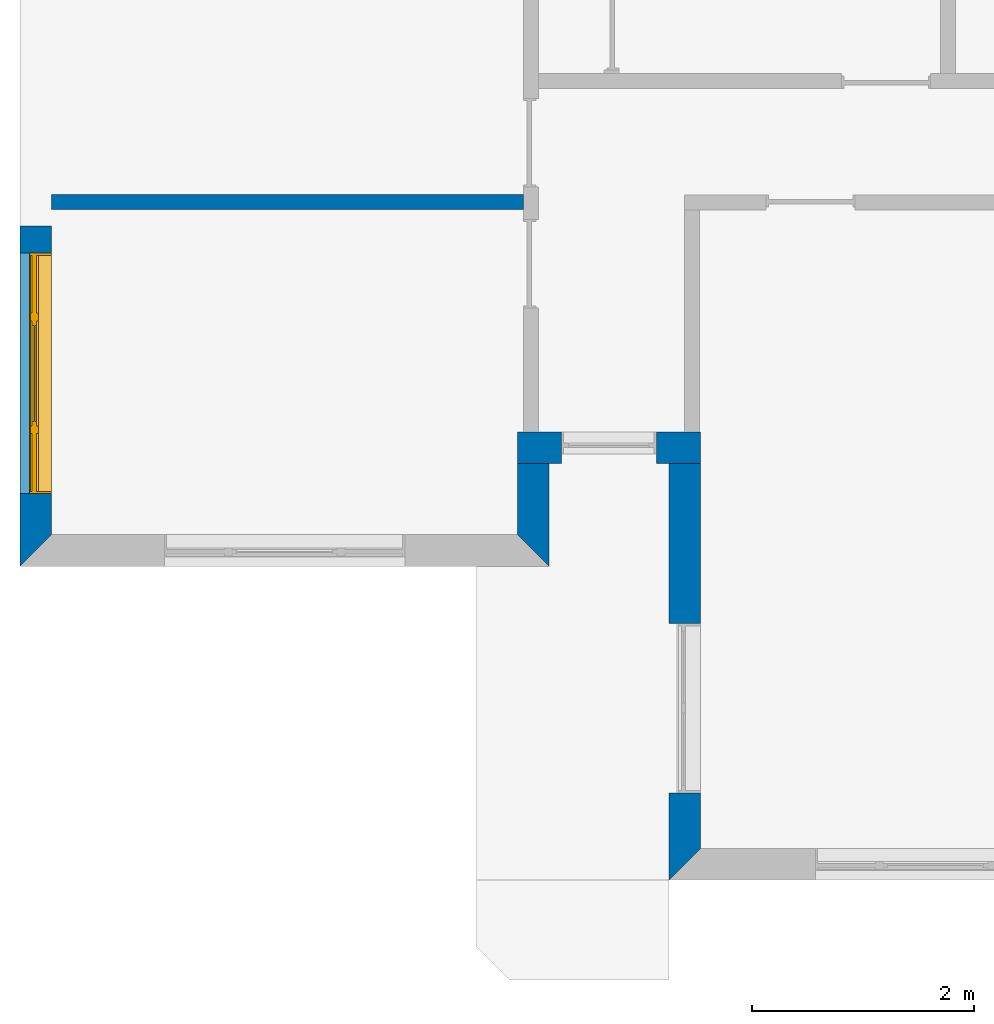
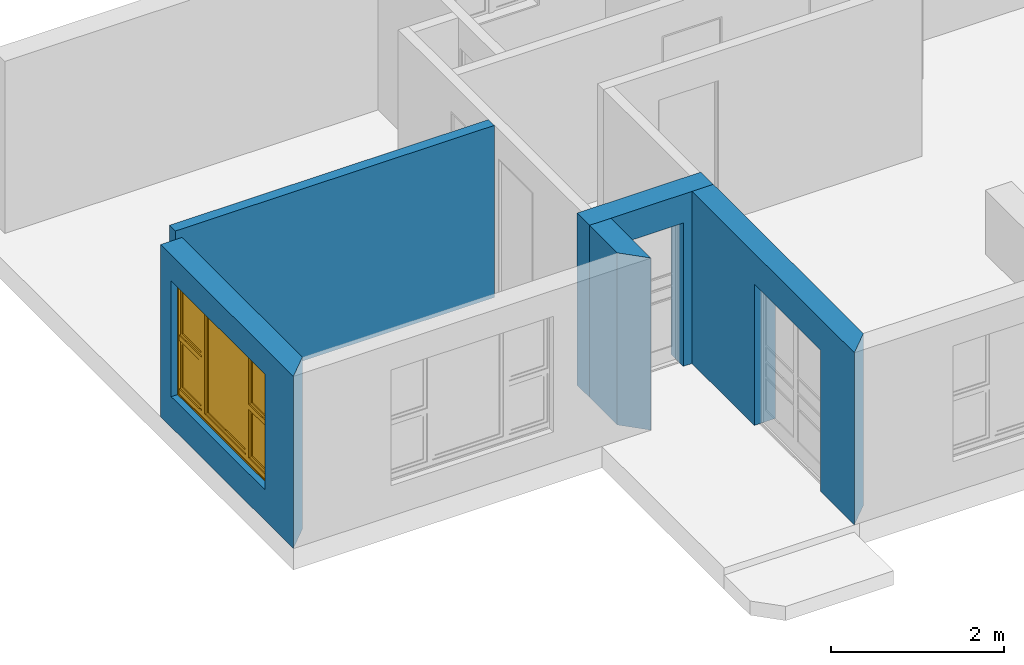
# One storey, part 2 of 15: 5 walls, 1 window, 3 openings.
"""IFC4 building model written with IfcOpenShell, lengths in millimetres."""

from ifc_helpers import new_model, entity, si_unit, converted_unit, frame, origin_with_axes, origin_2d_with_axis, place, context, subcontext, project, spatial, line, indexed_curve, outline, extrude, clip, halfspace, polygons, source, transform, mapped, material, layer, layer_set, layer_usage, type_object, type_shapes, element, fill, save


model = new_model("IFC4")

# Units and contexts
model_context = context("Model", 3, precision=1e-05, world=origin_with_axes())
plan_context = context("Plan", 2, precision=1e-05, world=origin_2d_with_axis())
body_context = subcontext(model_context, "Body", "Model", "MODEL_VIEW")
ifc_project = project(units=[si_unit("VOLUMEUNIT", "CUBIC_METRE"), si_unit("LENGTHUNIT", "METRE", prefix="MILLI"), converted_unit("PLANEANGLEUNIT", "degree", entity("IfcReal", 0.0174532925199433), si_unit("PLANEANGLEUNIT", "RADIAN"), dimensions=[0, 0, 0, 0, 0, 0, 0]), si_unit("AREAUNIT", "SQUARE_METRE")], contexts=[model_context, plan_context])

# Site, building, storey
site_placement = place(None, origin_with_axes())
site = spatial("IfcSite", under=ifc_project, at=site_placement)
building_placement = place(site_placement, origin_with_axes())
building = spatial("IfcBuilding", under=site, at=building_placement, Name="Building")
storey_placement = place(building_placement, origin_with_axes())
storey = spatial("IfcBuildingStorey", under=building, at=storey_placement, Name="EXISTING")

# Wall
ifc_material = material()
ifc_layer_1 = layer(ifc_material, 135.0)
ifc_layer_set_1 = layer_set([ifc_layer_1])
ifc_layer_usage_1 = layer_usage(ifc_layer_set_1, "AXIS2", "POSITIVE", 0.0)
wall_type_1 = type_object("IfcWallType", Name="WAL135", PredefinedType="NOTDEFINED", material=ifc_layer_set_1)
wall_1_placement = place(storey_placement, frame((34.11865234375, 1521.66748046875, 0.0), z_axis=(0.0, 0.0, 1.0), x_axis=(0.999999999999993, 1.19209282445353e-07, 0.0)))
element("IfcWall", 1, at=wall_1_placement, inside=storey, type_object=wall_type_1, material=ifc_layer_usage_1, Name="Wall", context=body_context, shape_type="SweptSolid", body=[
    extrude(outline(indexed_curve([(0.0, 0.0), (0.0, 135.0), (4250.0, 135.0), (4250.0, 0.0), (0.0, 0.0)], self_intersect=False)), origin_with_axes(), (0.0, 0.0, 1.0), 2425.00019073486),
])

# Wall, opening, window
ifc_layer_2 = layer(ifc_material, 285.0, Name="brick")
ifc_layer_set_2 = layer_set([ifc_layer_2])
ifc_layer_usage_2 = layer_usage(ifc_layer_set_2, "AXIS2", "POSITIVE", 0.0)
wall_type_2 = type_object("IfcWallType", Name="285mm Wall", PredefinedType="STANDARD", material=ifc_layer_set_2)
wall_2_placement = place(storey_placement, frame((34.11865234375, -1693.33076477051, 0.0), z_axis=(0.0, 0.0, 1.0), x_axis=(3.13916473260163e-07, 0.999999999999951, 0.0)))
wall_2 = element("IfcWall", 2, at=wall_2_placement, inside=storey, type_object=wall_type_2, material=ifc_layer_usage_2, Name="Wall", context=body_context, shape_type="Clipping", body=[
    clip(extrude(outline(indexed_curve([(0.0, 0.0), (0.0, 285.0), (3064.99893064013, 285.0), (3064.99893064013, 0.0), (0.0, 0.0)], self_intersect=False)), origin_with_axes(), (0.0, 0.0, 1.0), 2425.00019073486), halfspace(frame((284.999966621399, 4.93625407216314e-06, 0.0), z_axis=(-0.70710676908493, -0.707106709480286, 0.0), x_axis=(-0.707106751384223, 0.707106810988871, 0.0)), False)),
])
shared_shape_1 = source(origin_with_axes(), body_context, "Body", "SweptSolid", [
    extrude(outline(indexed_curve([(0.0, 0.0), (2165.00024414062, 0.0), (2165.00024414062, 1629.99987792969), (0.0, 1629.99987792969)], segments=[line(1, 2, 3, 4, 1)])), frame((-1.04308121251506e-07, -600.0, 0.0), z_axis=(0.0, -1.0, 0.0), x_axis=(1.0, 0.0, 0.0)), (0.0, 0.0, -1.0), 1200.0),
])
opening_1_placement = place(wall_2_placement, frame((655.528260222358, 148.88907685485, 430.000007152557), z_axis=(0.0, 0.0, 1.0), x_axis=(1.0, -5.29395592033938e-23, 0.0)))
opening_1 = element("IfcOpeningElement", 3, at=opening_1_placement, cuts=wall_2, Name="Opening", PredefinedType="OPENING", context=body_context, shape_type="MappedRepresentation", body=[
    mapped(shared_shape_1, transform((0.0, 0.0, 0.0), x_axis=(1.0, 0.0, 0.0), y_axis=(0.0, 1.0, 0.0), z_axis=(0.0, 0.0, 1.0), scale=1.0)),
])
window_type = type_object("IfcWindowType", Name="Ex.2165x1630", PartitioningType="NOTDEFINED", PredefinedType="WINDOW")
shared_shape_2 = source(origin_with_axes(), body_context, "Body", "Tessellation", [
    polygons([(2165.00048828125, -148.88883972168, 0.0), (2165.00048828125, -148.88883972168, 19.9999198913574), (0.000134110436192714, -148.888961791992, 0.0), (0.000134110436192714, -148.888961791992, 19.9999198913574), (2165.00048828125, 51.1111831665039, 0.0), (2165.00048828125, 51.1111831665039, 19.9999198913574), (0.000134110436192714, 51.1110649108887, 0.0), (0.000134110436192714, 51.1110649108887, 19.9999198913574), (2165.00048828125, -148.88883972168, 1609.99975585938), (2165.00048828125, -148.88883972168, 1630.0), (0.000134110436192714, -148.888961791992, 1609.99975585938), (0.000134110436192714, -148.888961791992, 1630.0), (2165.00048828125, 51.1111831665039, 1609.99975585938), (2165.00048828125, 51.1111831665039, 1630.0), (0.000134110436192714, 51.1110649108887, 1609.99975585938), (0.000134110436192714, 51.1110649108887, 1630.0), (0.000134110436192714, -148.88883972168, 19.9999198913574), (20.0003528594971, -148.88883972168, 19.9999198913574), (0.000134110436192714, -148.888961791992, 1609.99975585938), (20.000114440918, -148.888961791992, 1609.99975585938), (0.000134110436192714, 51.1111831665039, 19.9999198913574), (20.000114440918, 51.1111831665039, 19.9999198913574), (-0.000104308121080976, 51.1110649108887, 1609.99975585938), (20.000114440918, 51.1110649108887, 1609.99975585938), (2145.00048828125, -148.88883972168, 19.9999198913574), (2165.00048828125, -148.88883972168, 19.9999198913574), (2145.0, -148.888961791992, 1609.99975585938), (2165.0, -148.888961791992, 1609.99975585938), (2145.00048828125, 51.1111831665039, 19.9999198913574), (2165.00048828125, 51.1111831665039, 19.9999198913574), (2145.0, 51.1110649108887, 1609.99975585938), (2165.0, 51.1110649108887, 1609.99975585938), (1554.99987792969, -28.8888530731201, 19.9999198913574), (1625.0, -28.8888530731201, 19.9999198913574), (1554.99938964844, -28.8888530731201, 1609.99975585938), (1624.99951171875, -28.8888530731201, 1609.99975585938), (1554.99987792969, 41.1110763549805, 19.9999198913574), (1625.0, 41.1110763549805, 19.9999198913574), (1554.99938964844, 41.1110763549805, 1609.99975585938), (1624.99951171875, 41.1110763549805, 1609.99975585938), (540.000061035156, -28.8888530731201, 19.9999198913574), (610.000244140625, -28.8888530731201, 19.9999198913574), (539.999816894531, -28.8888530731201, 1609.99975585938), (610.0, -28.8888530731201, 1609.99975585938), (540.000061035156, 41.1110763549805, 19.9999198913574), (610.000244140625, 41.1110763549805, 19.9999198913574), (539.999816894531, 41.1110763549805, 1609.99975585938), (610.0, 41.1110763549805, 1609.99975585938), (20.000114440918, -28.888973236084, 844.999328613281), (20.000114440918, -28.888973236084, 775.000122070312), (540.000061035156, -28.8888530731201, 845.000061035156), (540.000061035156, -28.8888530731201, 775.000793457031), (20.000114440918, 41.1110763549805, 844.999328613281), (20.000114440918, 41.1110763549805, 775.000122070312), (540.000061035156, 41.1110763549805, 845.000061035156), (540.000061035156, 41.1111946105957, 775.000793457031), (1625.0, -28.888973236084, 844.999328613281), (1625.0, -28.888973236084, 775.000122070312), (2145.0, -28.8888530731201, 845.000061035156), (2145.0, -28.8888530731201, 775.000793457031), (1625.0, 41.1110763549805, 844.999328613281), (1625.0, 41.1110763549805, 775.000122070312), (2145.0, 41.1110763549805, 845.000061035156), (2145.0, 41.1111946105957, 775.000793457031), (1625.0, -13.8889875411987, 1609.99951171875), (1625.0, -13.8889875411987, 1569.99987792969), (2145.0, -13.8888683319092, 1609.99975585938), (2145.0, -13.8888683319092, 1570.00061035156), (1625.0, 26.1110916137695, 1609.99951171875), (1625.0, 26.1110916137695, 1569.99987792969), (2145.0, 26.1110916137695, 1610.00024414062), (2145.0, 26.1110916137695, 1570.00061035156), (1625.0, -13.8889875411987, 884.9990234375), (1625.0, -13.8889875411987, 844.999328613281), (2145.0, -13.8888683319092, 884.99951171875), (2145.0, -13.8888683319092, 844.999938964844), (1625.0, 26.1110916137695, 884.9990234375), (1625.0, 26.1110916137695, 844.999328613281), (2145.0, 26.1110916137695, 884.99951171875), (2145.0, 26.1110916137695, 844.999938964844), (1665.0, -13.8888683319092, 1570.00012207031), (1625.0, -13.8888683319092, 1570.00012207031), (1664.99975585938, -13.8888683319092, 884.9990234375), (1625.0, -13.8888683319092, 884.9990234375), (1665.0, 26.1110916137695, 1570.00012207031), (1625.0, 26.1110916137695, 1570.00012207031), (1664.99975585938, 26.1110916137695, 884.9990234375), (1625.0, 26.1110916137695, 884.9990234375), (2144.99951171875, -13.8888683319092, 1570.00012207031), (2105.00024414062, -13.8888683319092, 1570.00012207031), (2144.99951171875, -13.8888683319092, 884.9990234375), (2104.99975585938, -13.8888683319092, 884.9990234375), (2144.99951171875, 26.1110916137695, 1570.00012207031), (2105.00024414062, 26.1110916137695, 1570.00012207031), (2144.99951171875, 26.1110916137695, 884.9990234375), (2104.99975585938, 26.1110916137695, 884.9990234375), (20.0003528594971, -13.8889875411987, 1609.99951171875), (20.0003528594971, -13.8889875411987, 1569.99987792969), (540.000305175781, -13.8888683319092, 1609.99975585938), (540.000305175781, -13.8888683319092, 1570.00061035156), (20.0003528594971, 26.1110916137695, 1609.99951171875), (20.0003528594971, 26.1110916137695, 1569.99987792969), (540.000305175781, 26.1110916137695, 1610.00024414062), (540.000305175781, 26.1110916137695, 1570.00061035156), (20.0003528594971, -13.8889875411987, 884.9990234375), (20.0003528594971, -13.8889875411987, 844.999328613281), (540.000305175781, -13.8888683319092, 884.99951171875), (540.000305175781, -13.8888683319092, 844.999938964844), (20.0003528594971, 26.1110916137695, 884.9990234375), (20.0003528594971, 26.1110916137695, 844.999328613281), (540.000305175781, 26.1110916137695, 884.99951171875), (540.000305175781, 26.1110916137695, 844.999938964844), (60.0003128051758, -13.8888683319092, 1570.00012207031), (20.0005912780762, -13.8888683319092, 1570.00012207031), (60.000072479248, -13.8888683319092, 884.9990234375), (20.0005912780762, -13.8888683319092, 884.9990234375), (60.0003128051758, 26.1110916137695, 1570.00012207031), (20.0005912780762, 26.1110916137695, 1570.00012207031), (60.000072479248, 26.1110916137695, 884.9990234375), (20.0005912780762, 26.1110916137695, 884.9990234375), (539.999572753906, -13.8888683319092, 1570.00012207031), (499.999847412109, -13.8888683319092, 1570.00012207031), (539.999572753906, -13.8888683319092, 884.9990234375), (499.999603271484, -13.8888683319092, 884.9990234375), (539.999572753906, 26.1110916137695, 1570.00012207031), (499.999847412109, 26.1110916137695, 1570.00012207031), (539.999572753906, 26.1110916137695, 884.9990234375), (499.999603271484, 26.1110916137695, 884.9990234375), (20.000114440918, -28.888973236084, 89.9992523193359), (20.000114440918, -28.888973236084, 19.9997406005859), (540.000061035156, -28.8888530731201, 89.9999694824219), (540.000061035156, -28.8888530731201, 20.0004558563232), (20.000114440918, 41.1110763549805, 89.9992523193359), (20.000114440918, 41.1110763549805, 19.9997406005859), (540.000061035156, 41.1110763549805, 89.9999694824219), (540.000061035156, 41.1111946105957, 20.0004558563232), (1625.0, -28.888973236084, 89.9992523193359), (1625.0, -28.888973236084, 19.9997406005859), (2145.0, -28.8888530731201, 89.9999694824219), (2145.0, -28.8888530731201, 20.0004558563232), (1625.0, 41.1110763549805, 89.9992523193359), (1625.0, 41.1110763549805, 19.9997406005859), (2145.0, 41.1110763549805, 89.9999694824219), (2145.0, 41.1111946105957, 20.0004558563232), (610.000244140625, -28.888973236084, 89.9992523193359), (610.000244140625, -28.888973236084, 19.9997406005859), (1554.99987792969, -28.8888530731201, 89.9999694824219), (1554.99987792969, -28.8888530731201, 20.0004558563232), (610.000244140625, 41.1110763549805, 89.9992523193359), (610.000244140625, 41.1110763549805, 19.9997406005859), (1554.99987792969, 41.1110763549805, 89.9999694824219), (1554.99987792969, 41.1110763549805, 20.0004558563232), (1625.0, -13.8889875411987, 775.000244140625), (1625.0, -13.8889875411987, 735.000366210938), (2145.0, -13.8888683319092, 775.000793457031), (2145.0, -13.8888683319092, 735.001098632812), (1625.0, 26.1110916137695, 775.000244140625), (1625.0, 26.1110916137695, 735.000366210938), (2145.0, 26.1110916137695, 775.000793457031), (2145.0, 26.1110916137695, 735.001098632812), (1625.0, -13.8889875411987, 129.999694824219), (1625.0, -13.8889875411987, 89.9999694824219), (2145.0, -13.8888683319092, 130.00016784668), (2145.0, -13.8888683319092, 90.0005645751953), (1625.0, 26.1110916137695, 129.999694824219), (1625.0, 26.1110916137695, 89.9999694824219), (2145.0, 26.1110916137695, 130.00016784668), (2145.0, 26.1110916137695, 90.0005645751953), (1665.0, -13.8888683319092, 735.000610351562), (1625.0, -13.8888683319092, 735.000610351562), (1664.99975585938, -13.8888683319092, 129.998977661133), (1625.0, -13.8888683319092, 129.999099731445), (1665.0, 26.1110916137695, 735.000610351562), (1625.0, 26.1110916137695, 735.000610351562), (1664.99975585938, 26.1110916137695, 129.998977661133), (1625.0, 26.1110916137695, 129.999099731445), (2144.99951171875, -13.8888683319092, 735.000610351562), (2105.00024414062, -13.8888683319092, 735.000610351562), (2144.99951171875, -13.8888683319092, 129.998977661133), (2104.99975585938, -13.8888683319092, 129.999099731445), (2144.99951171875, 26.1110916137695, 735.000610351562), (2105.00024414062, 26.1110916137695, 735.000610351562), (2144.99951171875, 26.1110916137695, 129.998977661133), (2104.99975585938, 26.1110916137695, 129.999099731445), (20.0003528594971, -13.8889875411987, 775.000244140625), (20.0003528594971, -13.8889875411987, 735.000366210938), (540.000305175781, -13.8888683319092, 775.000793457031), (540.000305175781, -13.8888683319092, 735.001098632812), (20.0003528594971, 26.1110916137695, 775.000244140625), (20.0003528594971, 26.1110916137695, 735.000366210938), (540.000305175781, 26.1110916137695, 775.000793457031), (540.000305175781, 26.1110916137695, 735.001098632812), (20.0003528594971, -13.8889875411987, 129.998611450195), (20.0003528594971, -13.8889875411987, 89.9989547729492), (540.000305175781, -13.8888683319092, 129.999099731445), (540.000305175781, -13.8888683319092, 89.9994354248047), (20.0003528594971, 26.1110916137695, 129.998611450195), (20.0003528594971, 26.1110916137695, 89.9989547729492), (540.000305175781, 26.1110916137695, 129.999206542969), (540.000305175781, 26.1110916137695, 89.9994354248047), (60.0003128051758, -13.8888683319092, 735.000610351562), (20.0005912780762, -13.8888683319092, 735.000610351562), (60.000072479248, -13.8888683319092, 129.998977661133), (20.0005912780762, -13.8888683319092, 129.999099731445), (60.0003128051758, 26.1110916137695, 735.000610351562), (20.0005912780762, 26.1110916137695, 735.000610351562), (60.000072479248, 26.1110916137695, 129.998977661133), (20.0005912780762, 26.1110916137695, 129.999099731445), (539.999572753906, -13.8888683319092, 735.000610351562), (499.999847412109, -13.8888683319092, 735.000610351562), (539.999572753906, -13.8888683319092, 129.998977661133), (499.999603271484, -13.8888683319092, 129.999099731445), (539.999572753906, 26.1110916137695, 735.000610351562), (499.999847412109, 26.1110916137695, 735.000610351562), (539.999572753906, 26.1110916137695, 129.998977661133), (499.999603271484, 26.1110916137695, 129.999099731445), (610.000427246094, -13.8889875411987, 1609.99951171875), (610.000427246094, -13.8889875411987, 1569.99987792969), (1554.99987792969, -13.8888683319092, 1609.99975585938), (1554.99987792969, -13.8888683319092, 1570.00061035156), (610.000427246094, 26.1110916137695, 1609.99951171875), (610.000427246094, 26.1110916137695, 1569.99987792969), (1554.99987792969, 26.1110916137695, 1610.00024414062), (1554.99987792969, 26.1110916137695, 1570.00061035156), (610.000427246094, -13.8889875411987, 129.998916625977), (610.000427246094, -13.8889875411987, 89.9992523193359), (1554.99987792969, -13.8888683319092, 129.999389648438), (1554.99987792969, -13.8888683319092, 89.9997863769531), (610.000427246094, 26.1110916137695, 129.998916625977), (610.000427246094, 26.1110916137695, 89.9992523193359), (1554.99987792969, 26.1110916137695, 129.999389648438), (1554.99987792969, 26.1110916137695, 89.9997863769531), (650.000183105469, -13.8888683319092, 1570.00012207031), (610.000671386719, -13.8888683319092, 1570.00012207031), (650.000183105469, -13.8888683319092, 129.999572753906), (610.000427246094, -13.8888683319092, 129.999572753906), (650.000183105469, 26.1110916137695, 1570.00012207031), (610.000671386719, 26.1110916137695, 1570.00012207031), (650.000183105469, 26.1110916137695, 129.999572753906), (610.000427246094, 26.1110916137695, 129.999572753906), (1554.99987792969, -13.8888683319092, 1570.00012207031), (1515.00012207031, -13.8888683319092, 1570.00012207031), (1554.99987792969, -13.8888683319092, 129.999389648438), (1515.00012207031, -13.8888683319092, 129.999389648438), (1554.99987792969, 26.1110916137695, 1570.00012207031), (1515.00012207031, 26.1110916137695, 1570.00012207031), (1554.99987792969, 26.1110916137695, 129.999389648438), (1515.00012207031, 26.1110916137695, 129.999389648438), (1515.00012207031, 1.11111617088318, 1570.00012207031), (650.001586914062, 1.11111617088318, 1570.00012207031), (1515.00012207031, 1.11111617088318, 129.999450683594), (650.001342773438, 1.11111617088318, 129.999572753906), (1515.00012207031, 11.1111059188843, 1570.00012207031), (650.001586914062, 11.1111059188843, 1570.00012207031), (1515.00012207031, 11.1111059188843, 129.999450683594), (650.001342773438, 11.1111059188843, 129.999572753906), (2104.99877929688, 1.11111617088318, 1570.00012207031), (1665.0, 1.11111617088318, 1570.00012207031), (2104.99877929688, 1.11111617088318, 884.99951171875), (1664.99975585938, 1.11111617088318, 884.99951171875), (2104.99877929688, 11.1111059188843, 1570.00012207031), (1665.0, 11.1111059188843, 1570.00012207031), (2104.99877929688, 11.1111059188843, 884.99951171875), (1664.99975585938, 11.1111059188843, 884.99951171875), (2104.99877929688, 1.11111617088318, 735.000366210938), (1665.0, 1.11111617088318, 735.000610351562), (2104.99877929688, 1.11111617088318, 130.000518798828), (1664.99975585938, 1.11111617088318, 130.000518798828), (2104.99877929688, 11.1111059188843, 735.000366210938), (1665.0, 11.1111059188843, 735.000610351562), (2104.99877929688, 11.1111059188843, 130.000518798828), (1664.99975585938, 11.1111059188843, 130.000518798828), (499.998901367188, 1.11111617088318, 1570.00012207031), (60.0003128051758, 1.11111617088318, 1570.00012207031), (499.998657226562, 1.11111617088318, 884.99951171875), (60.000072479248, 1.11111617088318, 884.99951171875), (499.998901367188, 11.1111059188843, 1570.00012207031), (60.0003128051758, 11.1111059188843, 1570.00012207031), (499.998657226562, 11.1111059188843, 884.99951171875), (60.000072479248, 11.1111059188843, 884.99951171875), (499.998901367188, 1.11111617088318, 735.000366210938), (60.0003128051758, 1.11111617088318, 735.000610351562), (499.998657226562, 1.11111617088318, 130.000518798828), (60.000072479248, 1.11111617088318, 130.000518798828), (499.998901367188, 11.1111059188843, 735.000366210938), (60.0003128051758, 11.1111059188843, 735.000610351562), (499.998657226562, 11.1111059188843, 130.000518798828), (60.000072479248, 11.1111059188843, 130.000518798828)], [[[1, 2, 4, 3]], [[3, 4, 8, 7]], [[7, 8, 6, 5]], [[5, 6, 2, 1]], [[3, 7, 5, 1]], [[8, 4, 2, 6]], [[9, 10, 12, 11]], [[11, 12, 16, 15]], [[15, 16, 14, 13]], [[13, 14, 10, 9]], [[11, 15, 13, 9]], [[16, 12, 10, 14]], [[17, 18, 20, 19]], [[19, 20, 24, 23]], [[23, 24, 22, 21]], [[21, 22, 18, 17]], [[19, 23, 21, 17]], [[24, 20, 18, 22]], [[25, 26, 28, 27]], [[27, 28, 32, 31]], [[31, 32, 30, 29]], [[29, 30, 26, 25]], [[27, 31, 29, 25]], [[32, 28, 26, 30]], [[33, 34, 36, 35]], [[35, 36, 40, 39]], [[39, 40, 38, 37]], [[37, 38, 34, 33]], [[35, 39, 37, 33]], [[40, 36, 34, 38]], [[41, 42, 44, 43]], [[43, 44, 48, 47]], [[47, 48, 46, 45]], [[45, 46, 42, 41]], [[43, 47, 45, 41]], [[48, 44, 42, 46]], [[49, 50, 52, 51]], [[51, 52, 56, 55]], [[55, 56, 54, 53]], [[53, 54, 50, 49]], [[51, 55, 53, 49]], [[56, 52, 50, 54]], [[57, 58, 60, 59]], [[59, 60, 64, 63]], [[63, 64, 62, 61]], [[61, 62, 58, 57]], [[59, 63, 61, 57]], [[64, 60, 58, 62]], [[65, 66, 68, 67]], [[67, 68, 72, 71]], [[71, 72, 70, 69]], [[69, 70, 66, 65]], [[67, 71, 69, 65]], [[72, 68, 66, 70]], [[73, 74, 76, 75]], [[75, 76, 80, 79]], [[79, 80, 78, 77]], [[77, 78, 74, 73]], [[75, 79, 77, 73]], [[80, 76, 74, 78]], [[81, 82, 84, 83]], [[83, 84, 88, 87]], [[87, 88, 86, 85]], [[85, 86, 82, 81]], [[83, 87, 85, 81]], [[88, 84, 82, 86]], [[89, 90, 92, 91]], [[91, 92, 96, 95]], [[95, 96, 94, 93]], [[93, 94, 90, 89]], [[91, 95, 93, 89]], [[96, 92, 90, 94]], [[97, 98, 100, 99]], [[99, 100, 104, 103]], [[103, 104, 102, 101]], [[101, 102, 98, 97]], [[99, 103, 101, 97]], [[104, 100, 98, 102]], [[105, 106, 108, 107]], [[107, 108, 112, 111]], [[111, 112, 110, 109]], [[109, 110, 106, 105]], [[107, 111, 109, 105]], [[112, 108, 106, 110]], [[113, 114, 116, 115]], [[115, 116, 120, 119]], [[119, 120, 118, 117]], [[117, 118, 114, 113]], [[115, 119, 117, 113]], [[120, 116, 114, 118]], [[121, 122, 124, 123]], [[123, 124, 128, 127]], [[127, 128, 126, 125]], [[125, 126, 122, 121]], [[123, 127, 125, 121]], [[128, 124, 122, 126]], [[129, 130, 132, 131]], [[131, 132, 136, 135]], [[135, 136, 134, 133]], [[133, 134, 130, 129]], [[131, 135, 133, 129]], [[136, 132, 130, 134]], [[137, 138, 140, 139]], [[139, 140, 144, 143]], [[143, 144, 142, 141]], [[141, 142, 138, 137]], [[139, 143, 141, 137]], [[144, 140, 138, 142]], [[145, 146, 148, 147]], [[147, 148, 152, 151]], [[151, 152, 150, 149]], [[149, 150, 146, 145]], [[147, 151, 149, 145]], [[152, 148, 146, 150]], [[153, 154, 156, 155]], [[155, 156, 160, 159]], [[159, 160, 158, 157]], [[157, 158, 154, 153]], [[155, 159, 157, 153]], [[160, 156, 154, 158]], [[161, 162, 164, 163]], [[163, 164, 168, 167]], [[167, 168, 166, 165]], [[165, 166, 162, 161]], [[163, 167, 165, 161]], [[168, 164, 162, 166]], [[169, 170, 172, 171]], [[171, 172, 176, 175]], [[175, 176, 174, 173]], [[173, 174, 170, 169]], [[171, 175, 173, 169]], [[176, 172, 170, 174]], [[177, 178, 180, 179]], [[179, 180, 184, 183]], [[183, 184, 182, 181]], [[181, 182, 178, 177]], [[179, 183, 181, 177]], [[184, 180, 178, 182]], [[185, 186, 188, 187]], [[187, 188, 192, 191]], [[191, 192, 190, 189]], [[189, 190, 186, 185]], [[187, 191, 189, 185]], [[192, 188, 186, 190]], [[193, 194, 196, 195]], [[195, 196, 200, 199]], [[199, 200, 198, 197]], [[197, 198, 194, 193]], [[195, 199, 197, 193]], [[200, 196, 194, 198]], [[201, 202, 204, 203]], [[203, 204, 208, 207]], [[207, 208, 206, 205]], [[205, 206, 202, 201]], [[203, 207, 205, 201]], [[208, 204, 202, 206]], [[209, 210, 212, 211]], [[211, 212, 216, 215]], [[215, 216, 214, 213]], [[213, 214, 210, 209]], [[211, 215, 213, 209]], [[216, 212, 210, 214]], [[217, 218, 220, 219]], [[219, 220, 224, 223]], [[223, 224, 222, 221]], [[221, 222, 218, 217]], [[219, 223, 221, 217]], [[224, 220, 218, 222]], [[225, 226, 228, 227]], [[227, 228, 232, 231]], [[231, 232, 230, 229]], [[229, 230, 226, 225]], [[227, 231, 229, 225]], [[232, 228, 226, 230]], [[233, 234, 236, 235]], [[235, 236, 240, 239]], [[239, 240, 238, 237]], [[237, 238, 234, 233]], [[235, 239, 237, 233]], [[240, 236, 234, 238]], [[241, 242, 244, 243]], [[243, 244, 248, 247]], [[247, 248, 246, 245]], [[245, 246, 242, 241]], [[243, 247, 245, 241]], [[248, 244, 242, 246]], [[249, 250, 252, 251]], [[251, 252, 256, 255]], [[255, 256, 254, 253]], [[253, 254, 250, 249]], [[251, 255, 253, 249]], [[256, 252, 250, 254]], [[257, 258, 260, 259]], [[259, 260, 264, 263]], [[263, 264, 262, 261]], [[261, 262, 258, 257]], [[259, 263, 261, 257]], [[264, 260, 258, 262]], [[265, 266, 268, 267]], [[267, 268, 272, 271]], [[271, 272, 270, 269]], [[269, 270, 266, 265]], [[267, 271, 269, 265]], [[272, 268, 266, 270]], [[273, 274, 276, 275]], [[275, 276, 280, 279]], [[279, 280, 278, 277]], [[277, 278, 274, 273]], [[275, 279, 277, 273]], [[280, 276, 274, 278]], [[281, 282, 284, 283]], [[283, 284, 288, 287]], [[287, 288, 286, 285]], [[285, 286, 282, 281]], [[283, 287, 285, 281]], [[288, 284, 282, 286]]], closed=True),
])
type_shapes(window_type, [shared_shape_2])
window_placement = place(opening_1_placement, frame((-0.000238418789821893, 0.000670552178616557, 3.88578058618805e-13), z_axis=(0.0, 0.0, 1.0), x_axis=(1.0, 5.29395592033938e-23, 0.0)))
window = element("IfcWindow", 4, at=window_placement, inside=storey, type_object=window_type, Name="Window", context=body_context, shape_type="MappedRepresentation", body=[
    mapped(shared_shape_2, transform((0.0, 0.0, 0.0), x_axis=(1.0, 0.0, 0.0), y_axis=(0.0, 1.0, 0.0), z_axis=(0.0, 0.0, 1.0), scale=1.0)),
])
fill(opening_1, window)

# Wall
ifc_layer_usage_3 = layer_usage(ifc_layer_set_2, "AXIS2", "POSITIVE", 0.0)
wall_3_placement = place(storey_placement, frame((4514.12057876587, -1693.33219528198, 0.0), z_axis=(0.0, 0.0, 1.0), x_axis=(3.13916473260163e-07, 0.999999999999951, 0.0)))
element("IfcWall", 5, at=wall_3_placement, inside=storey, type_object=wall_type_2, material=ifc_layer_usage_3, Name="Wall", context=body_context, shape_type="Clipping", body=[
    clip(extrude(outline(indexed_curve([(0.0, 0.0), (0.0, 285.0), (924.999115917834, 285.0), (924.999115917834, 0.0), (0.0, 0.0)], self_intersect=False)), origin_with_axes(), (0.0, 0.0, 1.0), 2425.00019073486), halfspace(frame((8.02019712864421e-05, -9.41729716430473e-06, 0.0), z_axis=(-0.707106709480286, 0.70710676908493, 0.0), x_axis=(0.707106810988871, 0.707106751384223, 0.0)), False)),
])

# Wall, opening
ifc_layer_usage_4 = layer_usage(ifc_layer_set_2, "AXIS2", "POSITIVE", 0.0)
wall_4_placement = place(storey_placement, frame((5879.11891937256, -4518.33343505859, 0.0), z_axis=(0.0, 0.0, 1.0), x_axis=(3.13916473260163e-07, 0.999999999999951, 0.0)))
wall_4 = element("IfcWall", 6, at=wall_4_placement, inside=storey, type_object=wall_type_2, material=ifc_layer_usage_4, Name="Wall", context=body_context, shape_type="Clipping", body=[
    clip(extrude(outline(indexed_curve([(0.0, 0.0), (0.0, 285.0), (3750.00025431326, 285.0), (3750.00025431326, 0.0), (0.0, 0.0)], self_intersect=False)), origin_with_axes(), (0.0, 0.0, 1.0), 2425.00019073486), halfspace(frame((285.000115633011, -0.000329928298015147, 0.0), z_axis=(-0.707106828689575, -0.707106709480286, 0.0), x_axis=(-0.707106721581899, 0.707106840791191, 0.0)), False)),
])
shared_shape_3 = source(origin_with_axes(), body_context, "Body", "SweptSolid", [
    extrude(outline(indexed_curve([(0.0, 0.0), (1525.00061035156, 0.0), (1525.00061035156, 1989.99975585938), (0.0, 1989.99975585938)], segments=[line(1, 2, 3, 4, 1)])), frame((-3.27825517842939e-07, -600.0, 0.0), z_axis=(0.0, -1.0, 0.0), x_axis=(1.0, 0.0, 0.0)), (0.0, 0.0, -1.0), 1200.0),
])
opening_2_placement = place(wall_4_placement, frame((785.000324249383, -0.000230412628532406, 0.0), z_axis=(0.0, 0.0, 1.0), x_axis=(1.0, -5.29395592033938e-23, 0.0)))
element("IfcOpeningElement", 7, at=opening_2_placement, cuts=wall_4, PredefinedType="OPENING", context=body_context, shape_type="MappedRepresentation", body=[
    mapped(shared_shape_3, transform((0.0, 0.0, 0.0), x_axis=(1.0, 0.0, 0.0), y_axis=(0.0, 1.0, 0.0), z_axis=(0.0, 0.0, 1.0), scale=1.0)),
])

ifc_layer_usage_5 = layer_usage(ifc_layer_set_2, "AXIS2", "POSITIVE", 0.0)
wall_5_placement = place(storey_placement, frame((4229.12073135376, -768.332958221436, 0.0), z_axis=(0.0, 0.0, 1.0), x_axis=(0.999999999999972, -2.38418579101556e-07, 0.0)))
wall_5 = element("IfcWall", 8, at=wall_5_placement, inside=storey, type_object=wall_type_2, material=ifc_layer_usage_5, Name="Wall", context=body_context, shape_type="SweptSolid", body=[
    extrude(outline(indexed_curve([(0.0, 0.0), (0.0, 285.0), (1649.9991590325, 285.0), (1649.9991590325, 0.0), (0.0, 0.0)], self_intersect=False)), origin_with_axes(), (0.0, 0.0, 1.0), 2425.00019073486),
])
shared_shape_4 = source(origin_with_axes(), body_context, "Body", "SweptSolid", [
    extrude(outline(indexed_curve([(0.0, 0.0), (855.007202148438, 0.0), (855.007202148438, 2020.00012207031), (0.0, 2020.00012207031)], segments=[line(1, 2, 3, 4, 1)])), frame((1.34110436533774e-07, -600.0, 0.0), z_axis=(0.0, -1.0, 0.0), x_axis=(1.0, 0.0, 0.0)), (0.0, 0.0, -1.0), 1200.0),
])
opening_3_placement = place(wall_5_placement, frame((1250.00807848092, 170.333112282545, 0.0), z_axis=(0.0, 0.0, 1.0), x_axis=(-0.999999999999989, 1.50995788317222e-07, 0.0)))
element("IfcOpeningElement", 9, at=opening_3_placement, cuts=wall_5, PredefinedType="OPENING", context=body_context, shape_type="MappedRepresentation", body=[
    mapped(shared_shape_4, transform((0.0, 0.0, 0.0), x_axis=(1.0, 0.0, 0.0), y_axis=(0.0, 1.0, 0.0), z_axis=(0.0, 0.0, 1.0), scale=1.0)),
])

save(model, "model.ifc")
